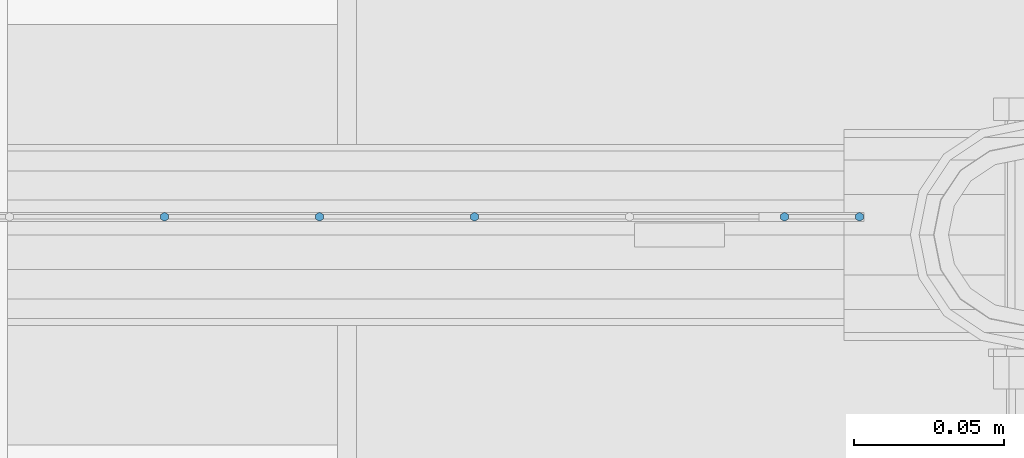
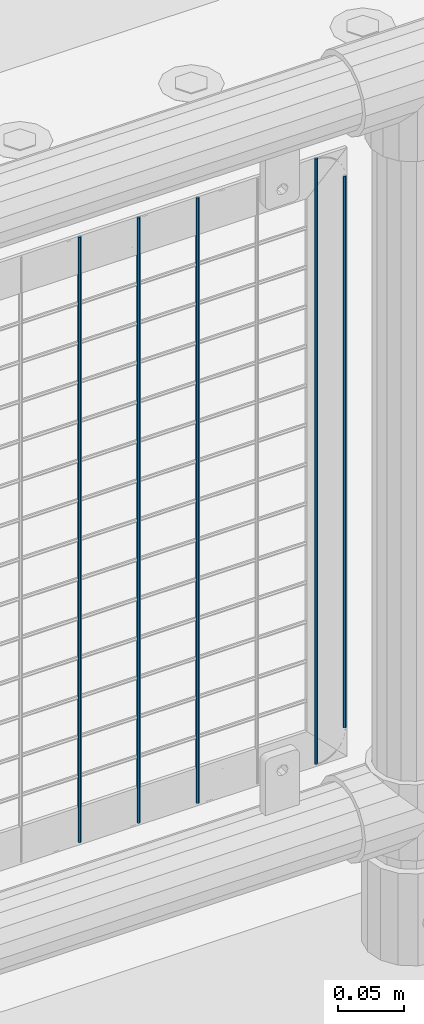
# One storey, part 68 of 219: 5 columns.
"""IFC2X3 building model written with IfcOpenShell, lengths in millimetres."""

from ifc_helpers import new_model, si_unit, frame, origin_with_axes, place, context, subcontext, project, spatial, faceted_brep, material, type_object, element, save


model = new_model("IFC2X3")

# Units and contexts
model_context = context("Model", 3, precision=1e-05, world=origin_with_axes())
body_context = subcontext(model_context, "Body", "Model", "MODEL_VIEW")
ifc_project = project(units=[si_unit("LENGTHUNIT", "METRE", prefix="MILLI"), si_unit("AREAUNIT", "SQUARE_METRE"), si_unit("VOLUMEUNIT", "CUBIC_METRE"), si_unit("MASSUNIT", "GRAM", prefix="KILO"), si_unit("TIMEUNIT", "SECOND"), si_unit("PLANEANGLEUNIT", "RADIAN"), si_unit("SOLIDANGLEUNIT", "STERADIAN"), si_unit("THERMODYNAMICTEMPERATUREUNIT", "DEGREE_CELSIUS"), si_unit("LUMINOUSINTENSITYUNIT", "LUMEN")], contexts=[model_context])

# Site, building, storey
site_placement = place(None, origin_with_axes())
site = spatial("IfcSite", under=ifc_project, at=site_placement, CompositionType="ELEMENT")
building_placement = place(site_placement, origin_with_axes())
building = spatial("IfcBuilding", under=site, at=building_placement, Name="Standard", CompositionType="ELEMENT")
storey_placement = place(building_placement, origin_with_axes())
storey = spatial("IfcBuildingStorey", under=building, at=storey_placement, Name="Undefined", CompositionType="ELEMENT", Elevation=0.0)

# Columns
ifc_material = material(Name="Misc_Undefined")
column_type = type_object("IfcColumnType", Name="D3", PredefinedType="NOTDEFINED")
for number, where, z_axis, x_axis in (
    (1, (2095.685, 31670.5, 353.02), (-1.0, 0.0, 0.0), (0.0, 0.0, 1.0)),
    (2, (2044.03, 31670.5, 353.02), (-1.0, 0.0, 0.0), (0.0, 0.0, 1.0)),
    (3, (1992.375, 31670.5, 353.02), (-1.0, 0.0, 0.0), (0.0, 0.0, 1.0)),
    (4, (2198.995, 31670.5, 353.02), (-1.0, 0.0, 0.0), (0.0, 0.0, 1.0)),
):
    element("IfcColumn", number, at=place(storey_placement, frame(where, z_axis=z_axis, x_axis=x_axis)), inside=storey, type_object=column_type, material=ifc_material, ObjectType="D3", context=body_context, shape_type="Brep", body=[
        faceted_brep([(0.0, -1.5, -5.6843418860808e-14), (0.0, -0.75, -1.29903810567669), (560.0, -0.75, -1.29903810567703), (560.0, -1.5, 0.0), (0.0, 0.75, -1.29903810567669), (560.0, 0.75, -1.29903810567703), (0.0, 1.5, -5.6843418860808e-14), (560.0, 1.5, 0.0), (0.0, 0.75, 1.29903810567669), (560.0, 0.75, 1.29903810567703), (0.0, -0.75, 1.29903810567669), (560.0, -0.75, 1.29903810567703)], [[[0, 1, 2, 3]], [[1, 4, 5, 2]], [[4, 6, 7, 5]], [[6, 8, 9, 7]], [[8, 10, 11, 9]], [[10, 0, 3, 11]], [[5, 7, 9, 11, 3, 2]], [[10, 8, 6, 4, 1, 0]]]),
    ])
column_placement = place(storey_placement, frame((2224.0, 31670.5, 378.02), z_axis=(-1.0, 0.0, 0.0), x_axis=(0.0, 0.0, 1.0)))
element("IfcColumn", 5, at=column_placement, inside=storey, type_object=column_type, material=ifc_material, ObjectType="D3", context=body_context, shape_type="Brep", body=[
    faceted_brep([(0.0, -1.5, -5.6843418860808e-14), (0.0, -0.75, -1.29903810567669), (510.0, -0.75, -1.29903810567703), (510.0, -1.5, 0.0), (0.0, 0.75, -1.29903810567669), (510.0, 0.75, -1.29903810567703), (0.0, 1.5, -5.6843418860808e-14), (510.0, 1.5, 0.0), (0.0, 0.75, 1.29903810567669), (510.0, 0.75, 1.29903810567703), (0.0, -0.75, 1.29903810567669), (510.0, -0.75, 1.29903810567703)], [[[0, 1, 2, 3]], [[1, 4, 5, 2]], [[4, 6, 7, 5]], [[6, 8, 9, 7]], [[8, 10, 11, 9]], [[10, 0, 3, 11]], [[5, 7, 9, 11, 3, 2]], [[10, 8, 6, 4, 1, 0]]]),
])

save(model, "model.ifc")
